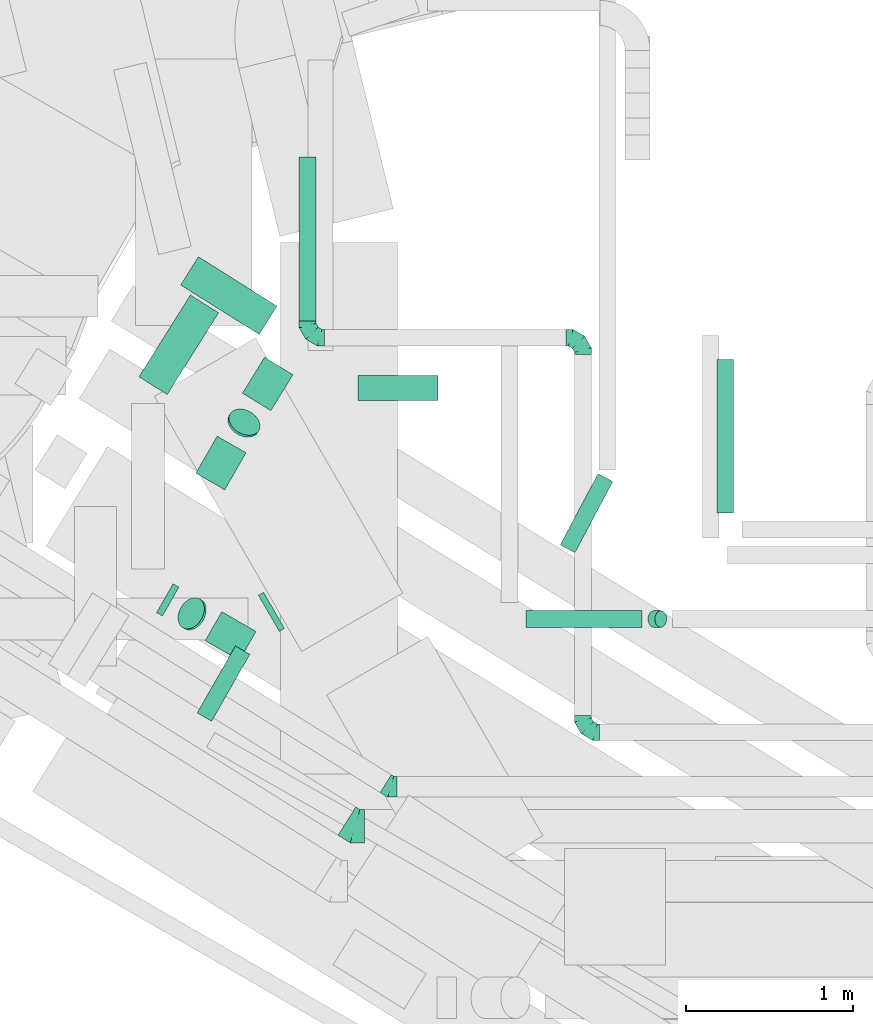
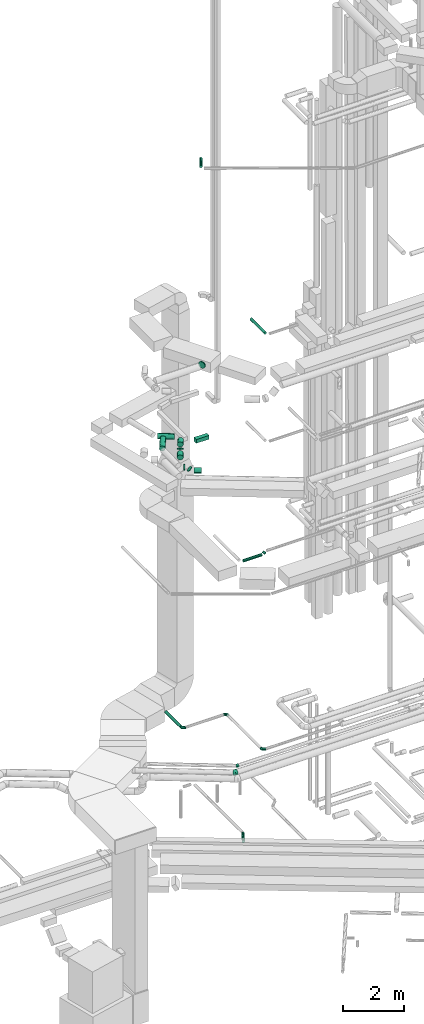
# One storey, part 89 of 337: 16 flow segments, 5 flow fittings.
"""IFC2X3 building model written with IfcOpenShell, lengths in millimetres."""

import ifcopenshell
import ifcopenshell.guid

model = None  # the IFC model being written
_history = None  # IfcOwnerHistory: only IFC2X3 demands one
_inside = {}  # id of a spatial element -> (the spatial element, [elements in it])
_under = {}  # id of a project, library or spatial element -> (it, [spatial elements below it])
_declared = {}  # id of a project -> (the project, [libraries it declares])
_typed = {}  # id of a type object -> (the type object, [elements of that type])
_made_of = {}  # id of a material, layer set ... -> (it, [elements and type objects made of it])


def new_model(schema):
    """Start an empty IFC model of exactly this schema.

    Asked for "IFC4X3", IfcOpenShell would pick the latest addendum, in which some entities
    have other attributes; the version numbers below select the first issue.
    IFC2X3 requires an IfcOwnerHistory on every rooted entity: one is made here for all.
    """
    global model, _history
    if schema == "IFC4X3":
        model = ifcopenshell.file(schema_version=(4, 3, 0, 0))
    else:
        model = ifcopenshell.file(schema=schema)
    _inside.clear()
    _under.clear()
    _declared.clear()
    _typed.clear()
    _made_of.clear()
    _history = None
    if model.schema == "IFC2X3":
        org = make("IfcOrganization", Name="unknown")
        user = make(
            "IfcPersonAndOrganization",
            ThePerson=make("IfcPerson", FamilyName="unknown"),
            TheOrganization=org,
        )
        app = make(
            "IfcApplication",
            ApplicationDeveloper=org,
            Version="unknown",
            ApplicationFullName="unknown",
            ApplicationIdentifier="unknown",
        )
        _history = make(
            "IfcOwnerHistory",
            OwningUser=user,
            OwningApplication=app,
            ChangeAction="ADDED",
            CreationDate=0,
        )
    return model


def make(cls, **values):
    """One entity of the class cls with the attributes given. An attribute that is None is left unset."""
    return model.create_entity(
        cls, **{name: value for name, value in values.items() if value is not None}
    )


def entity(cls, *values):
    """Any entity or typed value of the class cls, its attributes in the order of the schema. None: left unset."""
    e = model.create_entity(cls)
    for i, value in enumerate(values):
        if value is not None:
            e[i] = value
    return e


def rooted(cls, **values):
    """An entity with a GlobalId (a new one), such as an element, a storey or a relation."""
    return make(cls, GlobalId=ifcopenshell.guid.new(), OwnerHistory=_history, **values)


def si_unit(unit_type, name, prefix=None):
    """IfcSIUnit, for example si_unit("LENGTHUNIT", "METRE", prefix="MILLI")."""
    return make("IfcSIUnit", UnitType=unit_type, Prefix=prefix, Name=name)


def converted_unit(unit_type, name, factor, base, dimensions=None, offset=None):
    """IfcConversionBasedUnit, such as the inch: factor (a typed value) times the base unit."""
    return make(
        "IfcConversionBasedUnit"
        if offset is None
        else "IfcConversionBasedUnitWithOffset",
        ConversionOffset=offset,
        Dimensions=None
        if dimensions is None
        else entity("IfcDimensionalExponents", *dimensions),
        UnitType=unit_type,
        Name=name,
        ConversionFactor=make(
            "IfcMeasureWithUnit", ValueComponent=factor, UnitComponent=base
        ),
    )


def derived_unit(unit_type, elements):
    """IfcDerivedUnit: a product of units, each with its exponent."""
    return make(
        "IfcDerivedUnit",
        Elements=[
            make("IfcDerivedUnitElement", Unit=unit, Exponent=power)
            for unit, power in elements
        ],
        UnitType=unit_type,
    )


def assignment(units):
    """IfcUnitAssignment: the units of a project."""
    return None if units is None else make("IfcUnitAssignment", Units=units)


def point(xyz):
    """IfcCartesianPoint."""
    return None if xyz is None else make("IfcCartesianPoint", Coordinates=xyz)


def direction(xyz):
    """IfcDirection."""
    return None if xyz is None else make("IfcDirection", DirectionRatios=xyz)


def frame(location, z_axis=None, x_axis=None):
    """IfcAxis2Placement3D, a coordinate frame: its origin and axes. An axis left out is left unset."""
    return make(
        "IfcAxis2Placement3D",
        Location=point(location),
        Axis=direction(z_axis),
        RefDirection=direction(x_axis),
    )


def frame_2d(location, x_axis=None):
    """IfcAxis2Placement2D, a coordinate frame in the plane: its origin and x axis."""
    return make(
        "IfcAxis2Placement2D", Location=point(location), RefDirection=direction(x_axis)
    )


def origin():
    """The frame at (0, 0, 0) with its axes left unset."""
    return frame((0.0, 0.0, 0.0))


def origin_2d_with_axis():
    """The frame at (0, 0) in the plane with the x axis (1, 0) written out."""
    return frame_2d((0.0, 0.0), x_axis=(1.0, 0.0))


def place(relative_to, where):
    """IfcLocalPlacement: puts the frame where relative to a parent placement (None: the world)."""
    return make(
        "IfcLocalPlacement", PlacementRelTo=relative_to, RelativePlacement=where
    )


def context(
    kind, dimensions, precision=None, world=None, true_north=None, identifier=None
):
    """IfcGeometricRepresentationContext, for example the 3D "Model" context."""
    return make(
        "IfcGeometricRepresentationContext",
        ContextIdentifier=identifier,
        ContextType=kind,
        CoordinateSpaceDimension=dimensions,
        Precision=precision,
        WorldCoordinateSystem=world,
        TrueNorth=true_north,
    )


def subcontext(parent, identifier, kind, view, scale=None):
    """IfcGeometricRepresentationSubContext, for example "Body" below "Model"."""
    return make(
        "IfcGeometricRepresentationSubContext",
        ContextIdentifier=identifier,
        ContextType=kind,
        ParentContext=parent,
        TargetScale=scale,
        TargetView=view,
    )


def project(units=None, contexts=None):
    """IfcProject with its units and contexts."""
    return rooted(
        "IfcProject",
        Name="project",
        RepresentationContexts=contexts,
        UnitsInContext=assignment(units),
    )


def spatial(cls, under=None, at=None, **own):
    """A site, building, storey or space (cls), placed at a placement, below another one or the project."""
    s = rooted(cls, ObjectPlacement=at, **own)
    if under is not None:
        _under.setdefault(under.id(), (under, []))[1].append(s)
    return s


def profile(cls, at=None, kind="AREA", **sizes):
    """A parametric profile (cls). Its sizes go by their IFC names, for example OverallWidth=200.0."""
    return make(cls, ProfileType=kind, Position=at, **sizes)


def rectangle(**sizes):
    """IfcRectangleProfileDef."""
    return profile("IfcRectangleProfileDef", **sizes)


def circle(**sizes):
    """IfcCircleProfileDef."""
    return profile("IfcCircleProfileDef", **sizes)


def extrude(swept, where, along, depth):
    """IfcExtrudedAreaSolid: the profile swept, set in the frame where, extruded along a direction by depth."""
    return make(
        "IfcExtrudedAreaSolid",
        SweptArea=swept,
        Position=where,
        ExtrudedDirection=direction(along),
        Depth=depth,
    )


def faces_of(points, faces, orient=None, outer=None):
    """IfcFace entities. A face is a list of loops; a loop is a list of indices into points, from 0.

    orient and outer hold one flag for each loop. By default every Orientation is true, the
    first loop of a face is its IfcFaceOuterBound and the others are IfcFaceBound.
    """
    made = []
    for i, loops in enumerate(faces):
        bounds = []
        for j, loop in enumerate(loops):
            is_outer = j == 0 if outer is None else outer[i][j]
            bounds.append(
                make(
                    "IfcFaceOuterBound" if is_outer else "IfcFaceBound",
                    Bound=make("IfcPolyLoop", Polygon=[points[k] for k in loop]),
                    Orientation=True if orient is None else orient[i][j],
                )
            )
        made.append(make("IfcFace", Bounds=bounds))
    return made


def faceted_brep(points, faces, orient=None, outer=None, voids=None):
    """IfcFacetedBrep: a solid bounded by flat faces; with voids (closed shells), ...WithVoids."""
    shared = [point(p) for p in points]
    hull = make("IfcClosedShell", CfsFaces=faces_of(shared, faces, orient, outer))
    if voids is None:
        return make("IfcFacetedBrep", Outer=hull)
    return make(
        "IfcFacetedBrepWithVoids",
        Outer=hull,
        Voids=[
            make(cls, CfsFaces=faces_of(shared, fs, o, b)) for cls, fs, o, b in voids
        ],
    )


def shape(context_of_items, identifier, shape_type, items):
    """IfcShapeRepresentation: the items that make up one representation, for example the "Body"."""
    return make(
        "IfcShapeRepresentation",
        ContextOfItems=context_of_items,
        RepresentationIdentifier=identifier,
        RepresentationType=shape_type,
        Items=items,
    )


def source(mapping_origin, context_of_items, identifier, shape_type, items):
    """IfcRepresentationMap: a shape defined once, which mapped items show again and again."""
    return make(
        "IfcRepresentationMap",
        MappingOrigin=mapping_origin,
        MappedRepresentation=shape(context_of_items, identifier, shape_type, items),
    )


def transform(
    local_origin,
    x_axis=None,
    y_axis=None,
    z_axis=None,
    scale=None,
    scale2=None,
    scale3=None,
    uniform=True,
):
    """IfcCartesianTransformationOperator3D, or its non-uniform kind. x_axis, y_axis, z_axis: its Axis1, 2, 3."""
    if uniform:
        return make(
            "IfcCartesianTransformationOperator3D",
            Axis1=direction(x_axis),
            Axis2=direction(y_axis),
            LocalOrigin=point(local_origin),
            Scale=scale,
            Axis3=direction(z_axis),
        )
    return make(
        "IfcCartesianTransformationOperator3DnonUniform",
        Axis1=direction(x_axis),
        Axis2=direction(y_axis),
        LocalOrigin=point(local_origin),
        Scale=scale,
        Axis3=direction(z_axis),
        Scale2=scale2,
        Scale3=scale3,
    )


def mapped(mapping_source, mapping_target):
    """IfcMappedItem: shows the shape of a source again, moved by a transform."""
    return make(
        "IfcMappedItem", MappingSource=mapping_source, MappingTarget=mapping_target
    )


def material(Name=None, Category=None):
    """IfcMaterial."""
    return make("IfcMaterial", Name=Name, Category=Category)


def made_of(thing, what):
    """Note that an element or type object is made of a material, layer set ...; save() writes the relation."""
    if what is not None:
        _made_of.setdefault(what.id(), (what, []))[1].append(thing)
    return thing


def type_object(cls, material=None, **own):
    """A type object (cls), such as IfcWallType, which elements share."""
    return made_of(rooted(cls, **own), material)


def type_shapes(of_type, sources):
    """Give a type object the sources (RepresentationMaps) that its elements show as mapped items."""
    of_type.RepresentationMaps = sources


def element(
    cls,
    number,
    at=None,
    inside=None,
    cuts=None,
    type_object=None,
    material=None,
    context=None,
    identifier="Body",
    shape_type=None,
    held_by="IfcProductDefinitionShape",
    body=None,
    shapes=None,
    **own,
):
    """One element of the class cls, such as IfcWall. Its Tag is "e" and its number.

    at: its placement. inside: the storey or other place that contains it. cuts: it is an
    opening in that element (IfcRelVoidsElement). A single representation is given by context,
    identifier, shape_type and body (its items); several are given by shapes. held_by: the class
    of the entity that holds the representations. save() writes the other relations.
    """
    e = rooted(cls, Tag="e%d" % number, ObjectPlacement=at, **own)
    if body is not None:
        shapes = [shape(context, identifier, shape_type, body)]
    if shapes is not None:
        e.Representation = make(held_by, Representations=shapes)
    if inside is not None:
        _inside.setdefault(inside.id(), (inside, []))[1].append(e)
    if cuts is not None:
        rooted(
            "IfcRelVoidsElement", RelatingBuildingElement=cuts, RelatedOpeningElement=e
        )
    if type_object is not None:
        _typed.setdefault(type_object.id(), (type_object, []))[1].append(e)
    return made_of(e, material)


def aggregate(whole, parts):
    """IfcRelAggregates: a whole, such as a stair, and the parts it consists of."""
    return rooted("IfcRelAggregates", RelatingObject=whole, RelatedObjects=parts)


def save(model, path):
    """Write the relations noted so far, then the file.

    IfcRelAggregates (storeys below a building ...), IfcRelContainedInSpatialStructure (elements
    in a storey), IfcRelDefinesByType, IfcRelAssociatesMaterial and IfcRelDeclares: one each for
    every whole, place, type object, material and project.
    """
    for whole, parts in _under.values():
        aggregate(whole, parts)
    for where, things in _inside.values():
        rooted(
            "IfcRelContainedInSpatialStructure",
            RelatedElements=things,
            RelatingStructure=where,
        )
    for kind, things in _typed.values():
        rooted("IfcRelDefinesByType", RelatedObjects=things, RelatingType=kind)
    for what, things in _made_of.values():
        rooted("IfcRelAssociatesMaterial", RelatedObjects=things, RelatingMaterial=what)
    for by, libraries in _declared.values():
        rooted("IfcRelDeclares", RelatingContext=by, RelatedDefinitions=libraries)
    model.write(path)


model = new_model("IFC2X3")

# Units and contexts
model_context = context("Model", 3, precision=0.01, world=origin(), true_north=direction((6.12303176911189e-17, 1.0)))
body_context = subcontext(model_context, "Body", "Model", "MODEL_VIEW")
ifc_project = project(units=[si_unit("LENGTHUNIT", "METRE", prefix="MILLI"), si_unit("AREAUNIT", "SQUARE_METRE"), si_unit("VOLUMEUNIT", "CUBIC_METRE"), converted_unit("PLANEANGLEUNIT", "DEGREE", entity("IfcRatioMeasure", 0.0174532925199433), si_unit("PLANEANGLEUNIT", "RADIAN"), dimensions=[0, 0, 0, 0, 0, 0, 0]), si_unit("MASSUNIT", "GRAM", prefix="KILO"), derived_unit("MASSDENSITYUNIT", [(si_unit("MASSUNIT", "GRAM", prefix="KILO"), 1), (si_unit("LENGTHUNIT", "METRE"), -3)]), derived_unit("MOMENTOFINERTIAUNIT", [(si_unit("LENGTHUNIT", "METRE"), 4)]), si_unit("TIMEUNIT", "SECOND"), si_unit("FREQUENCYUNIT", "HERTZ"), si_unit("THERMODYNAMICTEMPERATUREUNIT", "DEGREE_CELSIUS"), derived_unit("THERMALTRANSMITTANCEUNIT", [(si_unit("MASSUNIT", "GRAM", prefix="KILO"), 1), (si_unit("THERMODYNAMICTEMPERATUREUNIT", "KELVIN"), -1), (si_unit("TIMEUNIT", "SECOND"), -3)]), derived_unit("VOLUMETRICFLOWRATEUNIT", [(si_unit("LENGTHUNIT", "METRE"), 3), (si_unit("TIMEUNIT", "SECOND"), -1)]), derived_unit("MASSFLOWRATEUNIT", [(si_unit("MASSUNIT", "GRAM", prefix="KILO"), 1), (si_unit("TIMEUNIT", "SECOND"), -1)]), derived_unit("ROTATIONALFREQUENCYUNIT", [(si_unit("TIMEUNIT", "SECOND"), -1)]), si_unit("ELECTRICCURRENTUNIT", "AMPERE"), si_unit("ELECTRICVOLTAGEUNIT", "VOLT"), si_unit("POWERUNIT", "WATT"), si_unit("FORCEUNIT", "NEWTON", prefix="KILO"), si_unit("ILLUMINANCEUNIT", "LUX"), si_unit("LUMINOUSFLUXUNIT", "LUMEN"), si_unit("LUMINOUSINTENSITYUNIT", "CANDELA"), derived_unit("USERDEFINED", [(si_unit("MASSUNIT", "GRAM", prefix="KILO"), -1), (si_unit("LENGTHUNIT", "METRE"), -2), (si_unit("TIMEUNIT", "SECOND"), 3), (si_unit("LUMINOUSFLUXUNIT", "LUMEN"), 1)]), derived_unit("LINEARVELOCITYUNIT", [(si_unit("LENGTHUNIT", "METRE"), 1), (si_unit("TIMEUNIT", "SECOND"), -1)]), si_unit("PRESSUREUNIT", "PASCAL"), derived_unit("USERDEFINED", [(si_unit("LENGTHUNIT", "METRE"), -2), (si_unit("MASSUNIT", "GRAM", prefix="KILO"), 1), (si_unit("TIMEUNIT", "SECOND"), -2)]), derived_unit("LINEARFORCEUNIT", [(si_unit("MASSUNIT", "GRAM", prefix="KILO"), 1), (si_unit("LENGTHUNIT", "METRE"), 1), (si_unit("TIMEUNIT", "SECOND"), -2), (si_unit("LENGTHUNIT", "METRE"), -1)]), derived_unit("PLANARFORCEUNIT", [(si_unit("MASSUNIT", "GRAM", prefix="KILO"), 1), (si_unit("LENGTHUNIT", "METRE"), 1), (si_unit("TIMEUNIT", "SECOND"), -2), (si_unit("LENGTHUNIT", "METRE"), -2)])], contexts=[model_context])

# Site, building, storey
site_placement = place(None, origin())
site = spatial("IfcSite", under=ifc_project, at=site_placement, CompositionType="ELEMENT")
building_placement = place(site_placement, origin())
building = spatial("IfcBuilding", under=site, at=building_placement, CompositionType="ELEMENT")
storey_placement = place(building_placement, origin())
storey = spatial("IfcBuildingStorey", under=building, at=storey_placement, CompositionType="ELEMENT", Elevation=0.0)

# Flow segments
duct_segment_type_1 = type_object("IfcDuctSegmentType", PredefinedType="NOTDEFINED")
flow_segment_1_placement = place(storey_placement, frame((3648.45, 14626.17, 15125.0)))
element("IfcFlowSegment", 1, at=flow_segment_1_placement, inside=storey, type_object=duct_segment_type_1, context=body_context, shape_type="SweptSolid", body=[
    extrude(rectangle(XDim=480.000000000001, YDim=150.000000000001, at=origin_2d_with_axis()), frame((240.0, 75.0, 0.0)), (0.0, 0.0, 1.0), 150.000000000001),
])
duct_segment_type_2 = type_object("IfcDuctSegmentType", PredefinedType="NOTDEFINED")
flow_segment_2_placement = place(storey_placement, frame((4859.54, 13711.44, -651.6)))
element("IfcFlowSegment", 2, at=flow_segment_2_placement, inside=storey, type_object=duct_segment_type_2, context=body_context, shape_type="SweptSolid", body=[
    extrude(circle(Radius=50.0, at=origin_2d_with_axis()), frame((45.74, 25.07, 51.6), z_axis=(0.46947156278594, 0.882947592858901, 0.0), x_axis=(-0.882947592858901, 0.46947156278594, 0.0)), (0.0, 0.0, 1.0), 482.925730281962),
])
flow_segment_3_placement = place(storey_placement, frame((2440.8, 13332.06, 15198.41)))
element("IfcFlowSegment", 3, at=flow_segment_3_placement, inside=storey, type_object=duct_segment_type_2, context=body_context, shape_type="SweptSolid", body=[
    extrude(circle(Radius=100.0, at=origin_2d_with_axis()), frame((51.02, 108.69, 101.6), z_axis=(0.869338108703612, -0.494217818284554, -2.90806157185383e-05), x_axis=(0.494213002825568, 0.869329894988976, -0.00436365862462737)), (0.0, 0.0, 1.0), 40.7978731880702),
])
flow_segment_4_placement = place(storey_placement, frame((2569.69, 13249.38, 15156.27)))
element("IfcFlowSegment", 4, at=flow_segment_4_placement, inside=storey, type_object=duct_segment_type_2, context=body_context, shape_type="SweptSolid", body=[
    extrude(circle(Radius=100.0, at=origin_2d_with_axis()), frame((91.37, 94.4, 72.31), z_axis=(-0.612372435695836, 0.353553390593215, 0.707106781186542), x_axis=(-0.499999999999951, -0.866025403784467, 0.0)), (0.0, 0.0, 1.0), 18.1612226388194),
])
flow_segment_5_placement = place(storey_placement, frame((2731.94, 13066.57, 15068.4)))
element("IfcFlowSegment", 5, at=flow_segment_5_placement, inside=storey, type_object=duct_segment_type_2, context=body_context, shape_type="SweptSolid", body=[
    extrude(circle(Radius=100.0, at=origin_2d_with_axis()), frame((256.49, 88.2, 101.6), z_axis=(-0.866025403784432, 0.500000000000012, 0.0), x_axis=(-0.500000000000012, -0.866025403784432, 0.0)), (0.0, 0.0, 1.0), 236.593222919894),
])
flow_segment_6_placement = place(storey_placement, frame((3295.6, 15101.08, 3628.4)))
element("IfcFlowSegment", 6, at=flow_segment_6_placement, inside=storey, type_object=duct_segment_type_2, context=body_context, shape_type="SweptSolid", body=[
    extrude(circle(Radius=50.0, at=origin_2d_with_axis()), frame((51.6, 0.0, 51.6), z_axis=(0.0, 1.0, 0.0), x_axis=(1.0, 0.0, 0.0)), (0.0, 0.0, 1.0), 982.499999999995),
])
flow_segment_7_placement = place(storey_placement, frame((2675.89, 14088.49, 15068.4)))
element("IfcFlowSegment", 7, at=flow_segment_7_placement, inside=storey, type_object=duct_segment_type_2, context=body_context, shape_type="SweptSolid", body=[
    extrude(circle(Radius=100.0, at=origin_2d_with_axis()), frame((88.2, 51.6, 101.6), z_axis=(0.500000371085545, 0.866025189537994, 0.0), x_axis=(-0.866025189537994, 0.500000371085545, 0.0)), (0.0, 0.0, 1.0), 256.101254102957),
])
flow_segment_8_placement = place(storey_placement, frame((2955.24, 14562.79, 15198.4)))
element("IfcFlowSegment", 8, at=flow_segment_8_placement, inside=storey, type_object=duct_segment_type_2, context=body_context, shape_type="SweptSolid", body=[
    extrude(circle(Radius=100.0, at=origin_2d_with_axis()), frame((86.76, 54.01, 101.6), z_axis=(0.524101117329906, 0.851656044899315, 0.0), x_axis=(0.851656044899315, -0.524101117329906, 0.0)), (0.0, 0.0, 1.0), 252.527612134696),
])
flow_segment_9_placement = place(storey_placement, frame((2868.14, 14403.84, 15156.33)))
element("IfcFlowSegment", 9, at=flow_segment_9_placement, inside=storey, type_object=duct_segment_type_2, context=body_context, shape_type="SweptSolid", body=[
    extrude(circle(Radius=100.0, at=origin_2d_with_axis()), frame((94.7, 80.51, 72.25), z_axis=(0.353553582220409, 0.612372161623665, 0.707106922726314), x_axis=(-0.851321046728555, 0.523894962607328, -0.0280453837852824)), (0.0, 0.0, 1.0), 18.1161330207346),
])
flow_segment_10_placement = place(storey_placement, frame((3051.03, 13239.59, 19073.4)))
element("IfcFlowSegment", 10, at=flow_segment_10_placement, inside=storey, type_object=duct_segment_type_2, context=body_context, shape_type="SweptSolid", body=[
    extrude(circle(Radius=125.0, at=origin_2d_with_axis()), frame((64.1, 109.85, 126.6), z_axis=(0.866025403784533, 0.499999999999837, 0.0), x_axis=(0.499999999999837, -0.866025403784533, 0.0)), (0.0, 0.0, 1.0), 36.2098195029389),
])
flow_segment_11_placement = place(storey_placement, frame((5798.85, 13950.35, 19098.4)))
element("IfcFlowSegment", 11, at=flow_segment_11_placement, inside=storey, type_object=duct_segment_type_2, context=body_context, shape_type="SweptSolid", body=[
    extrude(circle(Radius=50.0, at=origin_2d_with_axis()), frame((51.6, 0.0, 51.6), z_axis=(0.0, 1.0, 0.0), x_axis=(1.0, 0.0, 0.0)), (0.0, 0.0, 1.0), 920.000000000005),
])
flow_segment_12_placement = place(storey_placement, frame((4657.33, 13264.09, 10848.4)))
element("IfcFlowSegment", 12, at=flow_segment_12_placement, inside=storey, type_object=duct_segment_type_2, context=body_context, shape_type="SweptSolid", body=[
    extrude(circle(Radius=50.0, at=origin_2d_with_axis()), frame((0.0, 51.6, 51.6), z_axis=(1.0, 0.0, 0.0), x_axis=(0.0, -1.0, 0.0)), (0.0, 0.0, 1.0), 694.298647899979),
])
flow_segment_13_placement = place(storey_placement, frame((5385.39, 13264.09, 10892.34)))
element("IfcFlowSegment", 13, at=flow_segment_13_placement, inside=storey, type_object=duct_segment_type_2, context=body_context, shape_type="SweptSolid", body=[
    extrude(circle(Radius=50.0, at=origin_2d_with_axis()), frame((36.95, 51.6, 36.95), z_axis=(0.707106792500222, 0.0, 0.707106769872873), x_axis=(0.0, -1.0, 0.0)), (0.0, 0.0, 1.0), 58.5786478999585),
])
flow_segment_14_placement = place(storey_placement, frame((2584.96, 15019.73, 15198.4)))
element("IfcFlowSegment", 14, at=flow_segment_14_placement, inside=storey, type_object=duct_segment_type_2, context=body_context, shape_type="SweptSolid", body=[
    extrude(circle(Radius=100.0, at=origin_2d_with_axis()), frame((54.84, 382.3, 101.6), z_axis=(0.846485963007291, -0.532411038983621, 0.0), x_axis=(-0.532411038983621, -0.846485963007291, 0.0)), (0.0, 0.0, 1.0), 556.07320624615),
])
flow_segment_15_placement = place(storey_placement, frame((2335.12, 14659.36, 15198.4)))
element("IfcFlowSegment", 15, at=flow_segment_15_placement, inside=storey, type_object=duct_segment_type_2, context=body_context, shape_type="SweptSolid", body=[
    extrude(circle(Radius=100.0, at=origin_2d_with_axis()), frame((86.24, 54.84, 101.6), z_axis=(0.532411038983645, 0.846485963007276, 0.0), x_axis=(-0.846485963007276, 0.532411038983645, 0.0)), (0.0, 0.0, 1.0), 578.53791119199),
])
flow_segment_16_placement = place(storey_placement, frame((2683.93, 12701.85, 27548.4)))
element("IfcFlowSegment", 16, at=flow_segment_16_placement, inside=storey, type_object=duct_segment_type_2, context=body_context, shape_type="SweptSolid", body=[
    extrude(circle(Radius=50.0, at=origin_2d_with_axis()), frame((45.03, 26.36, 51.6), z_axis=(0.495368740427439, 0.86868280229744, 0.0), x_axis=(0.86868280229744, -0.495368740427439, 0.0)), (0.0, 0.0, 1.0), 461.843916699005),
])

# Flow fittings
ifc_material = material()
duct_fitting_type_1 = type_object("IfcDuctFittingType", PredefinedType="NOTDEFINED", material=ifc_material)
shared_shape_1 = source(origin(), body_context, "Body", "Brep", [
    faceted_brep([(-100.0, 0.0, -50.0), (-100.0, -12.94, -48.3), (-100.0, -25.0, -43.3), (-100.0, -35.36, -35.36), (-100.0, -43.3, -25.0), (-100.0, -48.3, -12.94), (-100.0, -50.0, 0.0), (-100.0, -48.3, 12.94), (-100.0, -43.3, 25.0), (-100.0, -35.36, 35.36), (-100.0, -25.0, 43.3), (-100.0, -12.94, 48.3), (-100.0, 0.0, 50.0), (-100.0, 12.94, 48.3), (-100.0, 25.0, 43.3), (-100.0, 35.36, 35.36), (-100.0, 43.3, 25.0), (-100.0, 48.3, 12.94), (-100.0, 50.0, 0.0), (-100.0, 48.3, -12.94), (-100.0, 43.3, -25.0), (-100.0, 35.36, -35.36), (-100.0, 25.0, -43.3), (-100.0, 12.94, -48.3), (-76.67, 12.94, 48.3), (-79.9, 25.0, 43.3), (-73.21, 0.0, 50.0), (-82.68, 35.36, 35.36), (-86.15, 48.3, 12.94), (-86.6, 50.0, 0.0), (-84.81, 43.3, 25.0), (-84.81, 43.3, -25.0), (-82.68, 35.36, -35.36), (-86.15, 48.3, -12.94), (-76.67, 12.94, -48.3), (-73.21, 0.0, -50.0), (-79.9, 25.0, -43.3), (-69.74, -12.94, -48.3), (-66.51, -25.0, -43.3), (-63.73, -35.36, -35.36), (-61.6, -43.3, -25.0), (-60.26, -48.3, -12.94), (-59.81, -50.0, 0.0), (-60.26, -48.3, 12.94), (-61.6, -43.3, 25.0), (-63.73, -35.36, 35.36), (-66.51, -25.0, 43.3), (-69.74, -12.94, 48.3), (-36.27, 36.27, 48.3), (-45.1, 45.1, 43.3), (-26.79, 26.79, 50.0), (-52.68, 52.68, 35.36), (-58.49, 58.49, 25.0), (-62.15, 62.15, 12.94), (-63.4, 63.4, 0.0), (-62.15, 62.15, -12.94), (-58.49, 58.49, -25.0), (-52.68, 52.68, -35.36), (-36.27, 36.27, -48.3), (-26.79, 26.79, -50.0), (-45.1, 45.1, -43.3), (-17.32, 17.32, -48.3), (-8.49, 8.49, -43.3), (-0.91, 0.91, -35.36), (4.9, -4.9, -25.0), (8.56, -8.56, -12.94), (9.81, -9.81, 0.0), (8.56, -8.56, 12.94), (4.9, -4.9, 25.0), (-0.91, 0.91, 35.36), (-8.49, 8.49, 43.3), (-17.32, 17.32, 48.3), (-12.94, 76.67, 48.3), (-25.0, 79.9, 43.3), (0.0, 73.21, 50.0), (-35.36, 82.68, 35.36), (-43.3, 84.81, 25.0), (-48.3, 86.15, 12.94), (-50.0, 86.6, 0.0), (-48.3, 86.15, -12.94), (-43.3, 84.81, -25.0), (-35.36, 82.68, -35.36), (-12.94, 76.67, -48.3), (0.0, 73.21, -50.0), (-25.0, 79.9, -43.3), (12.94, 69.74, -48.3), (25.0, 66.51, -43.3), (35.36, 63.73, -35.36), (43.3, 61.6, -25.0), (48.3, 60.26, -12.94), (50.0, 59.81, 0.0), (48.3, 60.26, 12.94), (43.3, 61.6, 25.0), (35.36, 63.73, 35.36), (25.0, 66.51, 43.3), (12.94, 69.74, 48.3), (-12.94, 100.0, -48.3), (-25.0, 100.0, -43.3), (-35.36, 100.0, -35.36), (-43.3, 100.0, -25.0), (-48.3, 100.0, -12.94), (-50.0, 100.0, 0.0), (-48.3, 100.0, 12.94), (-43.3, 100.0, 25.0), (-35.36, 100.0, 35.36), (-25.0, 100.0, 43.3), (-12.94, 100.0, 48.3), (0.0, 100.0, 50.0), (12.94, 100.0, 48.3), (25.0, 100.0, 43.3), (35.36, 100.0, 35.36), (43.3, 100.0, 25.0), (48.3, 100.0, 12.94), (50.0, 100.0, 0.0), (48.3, 100.0, -12.94), (43.3, 100.0, -25.0), (35.36, 100.0, -35.36), (25.0, 100.0, -43.3), (12.94, 100.0, -48.3), (0.0, 100.0, -50.0)], [[[0, 1, 2, 3, 4, 5, 6, 7, 8, 9, 10, 11, 12, 13, 14, 15, 16, 17, 18, 19, 20, 21, 22, 23]], [[24, 25, 14, 13]], [[26, 24, 13, 12]], [[14, 25, 27, 15]], [[28, 29, 18, 17]], [[30, 28, 17, 16]], [[15, 27, 30, 16]], [[20, 31, 32, 21]], [[33, 31, 20, 19]], [[18, 29, 33, 19]], [[34, 35, 0, 23]], [[36, 34, 23, 22]], [[32, 36, 22, 21]], [[2, 1, 37, 38]], [[3, 2, 38, 39]], [[0, 35, 37, 1]], [[5, 4, 40, 41]], [[6, 5, 41, 42]], [[3, 39, 40, 4]], [[6, 42, 43, 7]], [[7, 43, 44, 8]], [[8, 44, 45, 9]], [[10, 46, 47, 11]], [[11, 47, 26, 12]], [[10, 9, 45, 46]], [[48, 49, 25, 24]], [[50, 48, 24, 26]], [[27, 25, 49, 51]], [[52, 53, 28, 30]], [[51, 52, 30, 27]], [[29, 28, 53, 54]], [[55, 56, 31, 33]], [[54, 55, 33, 29]], [[57, 32, 31, 56]], [[58, 59, 35, 34]], [[60, 58, 34, 36]], [[57, 60, 36, 32]], [[37, 35, 59, 61]], [[38, 37, 61, 62]], [[39, 38, 62, 63]], [[41, 40, 64, 65]], [[42, 41, 65, 66]], [[63, 64, 40, 39]], [[43, 42, 66, 67]], [[44, 43, 67, 68]], [[68, 69, 45, 44]], [[46, 45, 69, 70]], [[47, 46, 70, 71]], [[26, 47, 71, 50]], [[72, 73, 49, 48]], [[74, 72, 48, 50]], [[51, 49, 73, 75]], [[76, 77, 53, 52]], [[75, 76, 52, 51]], [[54, 53, 77, 78]], [[79, 80, 56, 55]], [[78, 79, 55, 54]], [[81, 57, 56, 80]], [[82, 83, 59, 58]], [[84, 82, 58, 60]], [[81, 84, 60, 57]], [[61, 59, 83, 85]], [[62, 61, 85, 86]], [[63, 62, 86, 87]], [[65, 64, 88, 89]], [[66, 65, 89, 90]], [[87, 88, 64, 63]], [[67, 66, 90, 91]], [[68, 67, 91, 92]], [[92, 93, 69, 68]], [[70, 69, 93, 94]], [[71, 70, 94, 95]], [[50, 71, 95, 74]], [[96, 97, 98, 99, 100, 101, 102, 103, 104, 105, 106, 107, 108, 109, 110, 111, 112, 113, 114, 115, 116, 117, 118, 119]], [[72, 74, 107, 106]], [[73, 72, 106, 105]], [[75, 73, 105, 104]], [[77, 76, 103, 102]], [[78, 77, 102, 101]], [[75, 104, 103, 76]], [[78, 101, 100, 79]], [[79, 100, 99, 80]], [[80, 99, 98, 81]], [[96, 119, 83, 82]], [[97, 96, 82, 84]], [[84, 81, 98, 97]], [[83, 119, 118, 85]], [[85, 118, 117, 86]], [[86, 117, 116, 87]], [[88, 115, 114, 89]], [[89, 114, 113, 90]], [[87, 116, 115, 88]], [[91, 90, 113, 112]], [[92, 91, 112, 111]], [[93, 92, 111, 110]], [[95, 94, 109, 108]], [[74, 95, 108, 107]], [[110, 109, 94, 93]]]),
])
type_shapes(duct_fitting_type_1, [shared_shape_1])
for number, where, z_axis, x_axis in (
    (17, (4997.19, 15001.08, 3680.0), (0.0, 0.0, 1.0), (0.0, 1.0, 0.0)),
    (18, (3347.19, 15001.08, 3680.0), (0.0, 0.0, 1.0), (0.0, -1.0, 0.0)),
    (19, (4997.19, 12637.83, 3680.0), (0.0, 0.0, 1.0), (0.0, -1.0, 0.0)),
):
    element("IfcFlowFitting", number, at=place(storey_placement, frame(where, z_axis=z_axis, x_axis=x_axis)), inside=storey, type_object=duct_fitting_type_1, material=ifc_material, context=body_context, shape_type="MappedRepresentation", body=[
        mapped(shared_shape_1, transform((0.0, 0.0, 0.0), scale=1.0)),
    ])
duct_fitting_type_2 = type_object("IfcDuctFittingType", PredefinedType="NOTDEFINED", material=ifc_material)
shared_shape_2 = source(origin(), body_context, "Body", "Brep", [
    faceted_brep([(-57.35, 0.0, -100.0), (-57.35, -25.88, -96.59), (-57.35, -50.0, -86.6), (-57.35, -70.71, -70.71), (-57.35, -86.6, -50.0), (-57.35, -96.59, -25.88), (-57.35, -100.0, 0.0), (-57.35, -96.59, 25.88), (-57.35, -86.6, 50.0), (-57.35, -70.71, 70.71), (-57.35, -50.0, 86.6), (-57.35, -25.88, 96.59), (-57.35, 0.0, 100.0), (-57.35, 25.88, 96.59), (-57.35, 50.0, 86.6), (-57.35, 70.71, 70.71), (-57.35, 86.6, 50.0), (-57.35, 96.59, 25.88), (-57.35, 100.0, 0.0), (-57.35, 96.59, -25.88), (-57.35, 86.6, -50.0), (-57.35, 70.71, -70.71), (-57.35, 50.0, -86.6), (-57.35, 25.88, -96.59), (-7.42, 25.88, 96.59), (-14.34, 50.0, 86.6), (0.0, 0.0, 100.0), (-20.28, 70.71, 70.71), (-27.7, 96.59, 25.88), (-28.67, 100.0, 0.0), (-24.83, 86.6, 50.0), (-24.83, 86.6, -50.0), (-20.28, 70.71, -70.71), (-27.7, 96.59, -25.88), (-7.42, 25.88, -96.59), (0.0, 0.0, -100.0), (-14.34, 50.0, -86.6), (7.42, -25.88, -96.59), (14.34, -50.0, -86.6), (20.28, -70.71, -70.71), (24.83, -86.6, -50.0), (27.7, -96.59, -25.88), (28.67, -100.0, 0.0), (27.7, -96.59, 25.88), (24.83, -86.6, 50.0), (20.28, -70.71, 70.71), (14.34, -50.0, 86.6), (7.42, -25.88, 96.59), (48.63, 30.39, 100.0), (34.92, 52.34, 96.59), (22.14, 72.79, 86.6), (11.16, 90.36, 70.71), (-2.55, 112.31, 25.88), (-4.36, 115.19, 0.0), (2.74, 103.83, 50.0), (-2.55, 112.31, -25.88), (2.74, 103.83, -50.0), (11.16, 90.36, -70.71), (34.92, 52.34, -96.59), (48.63, 30.39, -100.0), (22.14, 72.79, -86.6), (62.35, 8.44, -96.59), (75.13, -12.01, -86.6), (86.1, -29.58, -70.71), (94.53, -43.05, -50.0), (99.82, -51.53, -25.88), (101.63, -54.42, 0.0), (99.82, -51.53, 25.88), (94.53, -43.05, 50.0), (86.1, -29.58, 70.71), (75.13, -12.01, 86.6), (62.35, 8.44, 96.59)], [[[0, 1, 2, 3, 4, 5, 6, 7, 8, 9, 10, 11, 12, 13, 14, 15, 16, 17, 18, 19, 20, 21, 22, 23]], [[24, 25, 14, 13]], [[26, 24, 13, 12]], [[14, 25, 27, 15]], [[28, 29, 18, 17]], [[30, 28, 17, 16]], [[16, 15, 27, 30]], [[20, 31, 32, 21]], [[33, 31, 20, 19]], [[18, 29, 33, 19]], [[34, 35, 0, 23]], [[36, 34, 23, 22]], [[32, 36, 22, 21]], [[1, 0, 35, 37]], [[2, 1, 37, 38]], [[3, 2, 38, 39]], [[5, 4, 40, 41]], [[6, 5, 41, 42]], [[39, 40, 4, 3]], [[6, 42, 43, 7]], [[7, 43, 44, 8]], [[8, 44, 45, 9]], [[9, 45, 46, 10]], [[10, 46, 47, 11]], [[26, 12, 11, 47]], [[24, 26, 48, 49]], [[25, 24, 49, 50]], [[27, 25, 50, 51]], [[52, 53, 29, 28]], [[54, 52, 28, 30]], [[27, 51, 54, 30]], [[29, 53, 55, 33]], [[33, 55, 56, 31]], [[31, 56, 57, 32]], [[58, 59, 35, 34]], [[60, 58, 34, 36]], [[36, 32, 57, 60]], [[61, 62, 38, 37]], [[59, 61, 37, 35]], [[63, 39, 38, 62]], [[40, 64, 65, 41]], [[41, 65, 66, 42]], [[64, 40, 39, 63]], [[43, 42, 66, 67]], [[44, 43, 67, 68]], [[68, 69, 45, 44]], [[47, 46, 70, 71]], [[26, 47, 71, 48]], [[69, 70, 46, 45]], [[58, 60, 57, 56, 55, 53, 52, 54, 51, 50, 49, 48, 71, 70, 69, 68, 67, 66, 65, 64, 63, 62, 61, 59]]]),
])
type_shapes(duct_fitting_type_2, [shared_shape_2])
flow_fitting_1_placement = place(storey_placement, frame((3631.8, 12074.54, 3600.0), z_axis=(9.11484719446874e-08, 7.32715854426224e-07, 1.0), x_axis=(0.848052743777523, -0.529911826412016, 3.10976084936305e-07)))
element("IfcFlowFitting", 20, at=flow_fitting_1_placement, inside=storey, type_object=duct_fitting_type_2, material=ifc_material, context=body_context, shape_type="MappedRepresentation", body=[
    mapped(shared_shape_2, transform((0.0, 0.0, 0.0), scale=1.0)),
])
duct_fitting_type_3 = type_object("IfcDuctFittingType", PredefinedType="NOTDEFINED", material=ifc_material)
shared_shape_3 = source(origin(), body_context, "Body", "Brep", [
    faceted_brep([(-35.84, 0.0, -62.5), (-35.84, -16.18, -60.37), (-35.84, -31.25, -54.13), (-35.84, -44.19, -44.19), (-35.84, -54.13, -31.25), (-35.84, -60.37, -16.18), (-35.84, -62.5, 0.0), (-35.84, -60.37, 16.18), (-35.84, -54.13, 31.25), (-35.84, -44.19, 44.19), (-35.84, -31.25, 54.13), (-35.84, -16.18, 60.37), (-35.84, 0.0, 62.5), (-35.84, 16.18, 60.37), (-35.84, 31.25, 54.13), (-35.84, 44.19, 44.19), (-35.84, 54.13, 31.25), (-35.84, 60.37, 16.18), (-35.84, 62.5, 0.0), (-35.84, 60.37, -16.18), (-35.84, 54.13, -31.25), (-35.84, 44.19, -44.19), (-35.84, 31.25, -54.13), (-35.84, 16.18, -60.37), (-4.64, 16.18, 60.37), (-8.96, 31.25, 54.13), (0.0, 0.0, 62.5), (-12.67, 44.19, 44.19), (-17.31, 60.37, 16.18), (-17.92, 62.5, 0.0), (-15.52, 54.13, 31.25), (-15.52, 54.13, -31.25), (-12.67, 44.19, -44.19), (-17.31, 60.37, -16.18), (-4.64, 16.18, -60.37), (0.0, 0.0, -62.5), (-8.96, 31.25, -54.13), (4.64, -16.18, -60.37), (8.96, -31.25, -54.13), (12.67, -44.19, -44.19), (15.52, -54.13, -31.25), (17.31, -60.37, -16.18), (17.92, -62.5, 0.0), (17.31, -60.37, 16.18), (15.52, -54.13, 31.25), (12.67, -44.19, 44.19), (8.96, -31.25, 54.13), (4.64, -16.18, 60.37), (30.4, 18.99, 62.5), (21.82, 32.71, 60.37), (13.84, 45.5, 54.13), (6.98, 56.47, 44.19), (1.71, 64.9, 31.25), (-1.59, 70.19, 16.18), (-2.72, 72.0, 0.0), (-1.59, 70.19, -16.18), (1.71, 64.9, -31.25), (6.98, 56.47, -44.19), (13.84, 45.5, -54.13), (21.82, 32.71, -60.37), (30.4, 18.99, -62.5), (38.97, 5.28, -60.37), (46.96, -7.51, -54.13), (53.82, -18.49, -44.19), (59.08, -26.91, -31.25), (62.39, -32.2, -16.18), (63.52, -34.01, 0.0), (62.39, -32.2, 16.18), (59.08, -26.91, 31.25), (53.82, -18.49, 44.19), (46.96, -7.51, 54.13), (38.97, 5.28, 60.37)], [[[0, 1, 2, 3, 4, 5, 6, 7, 8, 9, 10, 11, 12, 13, 14, 15, 16, 17, 18, 19, 20, 21, 22, 23]], [[24, 25, 14, 13]], [[26, 24, 13, 12]], [[14, 25, 27, 15]], [[28, 29, 18, 17]], [[30, 28, 17, 16]], [[15, 27, 30, 16]], [[20, 31, 32, 21]], [[33, 31, 20, 19]], [[18, 29, 33, 19]], [[34, 35, 0, 23]], [[36, 34, 23, 22]], [[21, 32, 36, 22]], [[1, 0, 35, 37]], [[2, 1, 37, 38]], [[3, 2, 38, 39]], [[5, 4, 40, 41]], [[6, 5, 41, 42]], [[39, 40, 4, 3]], [[6, 42, 43, 7]], [[7, 43, 44, 8]], [[45, 9, 8, 44]], [[9, 45, 46, 10]], [[10, 46, 47, 11]], [[26, 12, 11, 47]], [[24, 26, 48, 49]], [[25, 24, 49, 50]], [[27, 25, 50, 51]], [[28, 30, 52, 53]], [[29, 28, 53, 54]], [[27, 51, 52, 30]], [[29, 54, 55, 33]], [[33, 55, 56, 31]], [[31, 56, 57, 32]], [[36, 58, 59, 34]], [[34, 59, 60, 35]], [[36, 32, 57, 58]], [[35, 60, 61, 37]], [[37, 61, 62, 38]], [[63, 39, 38, 62]], [[40, 64, 65, 41]], [[41, 65, 66, 42]], [[64, 40, 39, 63]], [[67, 68, 44, 43]], [[66, 67, 43, 42]], [[68, 69, 45, 44]], [[47, 46, 70, 71]], [[26, 47, 71, 48]], [[69, 70, 46, 45]], [[59, 58, 57, 56, 55, 54, 53, 52, 51, 50, 49, 48, 71, 70, 69, 68, 67, 66, 65, 64, 63, 62, 61, 60]]]),
])
type_shapes(duct_fitting_type_3, [shared_shape_3])
flow_fitting_2_placement = place(storey_placement, frame((3845.81, 12310.36, 3650.0), z_axis=(0.0, 0.0, 1.0), x_axis=(0.848052743777569, -0.529911826412033, 0.0)))
element("IfcFlowFitting", 21, at=flow_fitting_2_placement, inside=storey, type_object=duct_fitting_type_3, material=ifc_material, context=body_context, shape_type="MappedRepresentation", body=[
    mapped(shared_shape_3, transform((0.0, 0.0, 0.0), scale=1.0)),
])

save(model, "model.ifc")
